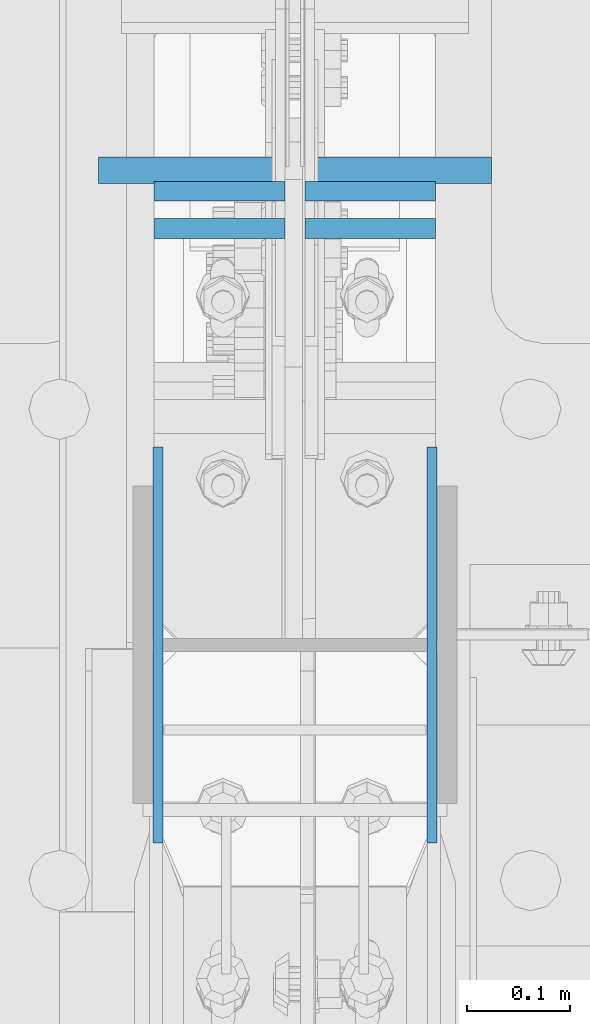
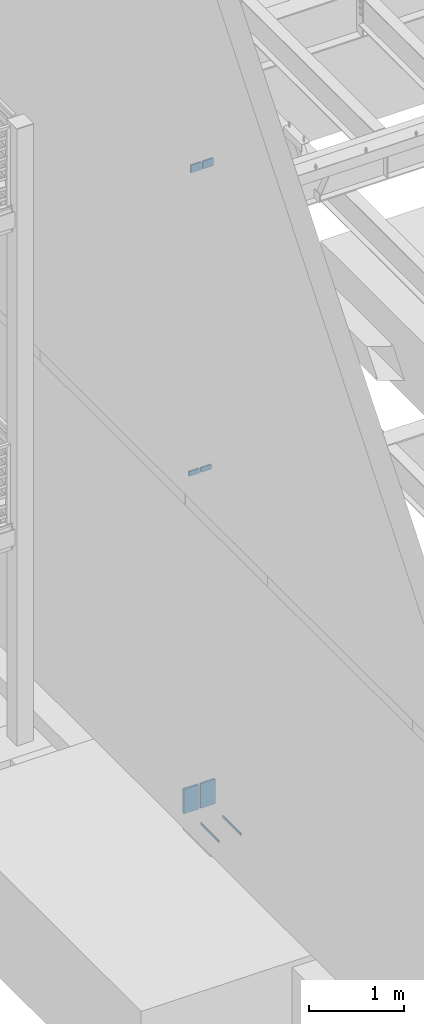
# One storey, part 422 of 1179: 8 columns, 3 elements without a shape of their own.
"""IFC2X3 building model written with IfcOpenShell, lengths in millimetres."""

from ifc_helpers import new_model, si_unit, frame, origin_with_axes, place, context, subcontext, project, spatial, faceted_brep, material, type_object, element, aggregate, save


model = new_model("IFC2X3")

# Units and contexts
model_context = context("Model", 3, precision=1e-05, world=origin_with_axes())
body_context = subcontext(model_context, "Body", "Model", "MODEL_VIEW")
ifc_project = project(units=[si_unit("LENGTHUNIT", "METRE", prefix="MILLI"), si_unit("AREAUNIT", "SQUARE_METRE"), si_unit("VOLUMEUNIT", "CUBIC_METRE"), si_unit("MASSUNIT", "GRAM", prefix="KILO"), si_unit("TIMEUNIT", "SECOND"), si_unit("PLANEANGLEUNIT", "RADIAN"), si_unit("SOLIDANGLEUNIT", "STERADIAN"), si_unit("THERMODYNAMICTEMPERATUREUNIT", "DEGREE_CELSIUS"), si_unit("LUMINOUSINTENSITYUNIT", "LUMEN")], contexts=[model_context])

# Site, building, storey
site_placement = place(None, origin_with_axes())
site = spatial("IfcSite", under=ifc_project, at=site_placement, CompositionType="ELEMENT")
building_placement = place(site_placement, origin_with_axes())
building = spatial("IfcBuilding", under=site, at=building_placement, Name="Undefined", CompositionType="ELEMENT")
storey_placement = place(building_placement, origin_with_axes())
storey = spatial("IfcBuildingStorey", under=building, at=storey_placement, Name="Undefined", CompositionType="ELEMENT", Elevation=0.0)

# Assembly, columns
assembly_1_placement = place(storey_placement, origin_with_axes())
assembly_1 = element("IfcElementAssembly", 1, at=assembly_1_placement, inside=storey, Name="COLUMN", AssemblyPlace="NOTDEFINED", PredefinedType="RIGID_FRAME")
ifc_material = material(Name="STEEL/A572-GR.50")
column_type_1 = type_object("IfcColumnType", PredefinedType="NOTDEFINED")
column_1_placement = place(assembly_1_placement, frame((564.753000000001, 27051.0, -215.9), z_axis=(0.0, -1.0, 0.0), x_axis=(0.0, 0.0, 1.0)))
column_1 = element("IfcColumn", 2, at=column_1_placement, type_object=column_type_1, material=ifc_material, Name="PLATE", context=body_context, shape_type="Brep", body=[
    faceted_brep([(0.0, 4.76249999999982, -192.087500000001), (0.0, 4.76249999999982, 192.0875), (31.75, 4.76249999999982, 192.0875), (31.75, 4.76249999999982, -192.087500000001), (0.0, -4.76249999999982, 192.0875), (31.75, -4.76249999999982, 192.0875), (0.0, -4.76249999999982, -192.087500000001), (31.75, -4.76249999999982, -192.087500000001)], [[[0, 1, 2, 3]], [[1, 4, 5, 2]], [[4, 6, 7, 5]], [[6, 0, 3, 7]], [[5, 7, 3, 2]], [[6, 4, 1, 0]]]),
])
column_2_placement = place(assembly_1_placement, frame((298.846874999998, 27051.0, -215.9), z_axis=(0.0, -1.0, 0.0), x_axis=(0.0, 0.0, 1.0)))
column_2 = element("IfcColumn", 3, at=column_2_placement, type_object=column_type_1, material=ifc_material, Name="PLATE", context=body_context, shape_type="Brep", body=[
    faceted_brep([(0.0, 4.76249999999982, -192.087500000001), (0.0, 4.76249999999982, 192.0875), (31.75, 4.76249999999982, 192.0875), (31.75, 4.76249999999982, -192.087500000001), (0.0, -4.76249999999982, 192.0875), (31.75, -4.76249999999982, 192.0875), (0.0, -4.76249999999982, -192.087500000001), (31.75, -4.76249999999982, -192.087500000001)], [[[0, 1, 2, 3]], [[1, 4, 5, 2]], [[4, 6, 7, 5]], [[6, 0, 3, 7]], [[5, 7, 3, 2]], [[6, 4, 1, 0]]]),
])
column_type_2 = type_object("IfcColumnType", PredefinedType="NOTDEFINED")
column_3_placement = place(assembly_1_placement, frame((358.774999999999, 27454.8139034115, 8013.7), z_axis=(-1.0, 0.0, 0.0), x_axis=(0.0, 0.0, 1.0)))
column_3 = element("IfcColumn", 4, at=column_3_placement, type_object=column_type_2, material=ifc_material, Name="PLATE", context=body_context, shape_type="Brep", body=[
    faceted_brep([(0.0, 9.52500000000146, -63.5), (0.0, 9.52500000000146, 63.5), (97.946337981949, 9.52500000000146, 63.5), (97.946337981949, 9.52500000000146, -63.5), (0.0, -9.52500000000146, 63.5), (97.946337981949, -9.52500000000146, 63.5), (0.0, -9.52500000000146, -63.5), (97.946337981949, -9.52500000000146, -63.5)], [[[0, 1, 2, 3]], [[1, 4, 5, 2]], [[4, 6, 7, 5]], [[6, 0, 3, 7]], [[5, 7, 3, 2]], [[6, 4, 1, 0]]]),
])
column_4_placement = place(assembly_1_placement, frame((504.824999999999, 27454.8139034115, 8013.7), z_axis=(-1.0, 0.0, 0.0), x_axis=(0.0, 0.0, 1.0)))
column_4 = element("IfcColumn", 5, at=column_4_placement, type_object=column_type_2, material=ifc_material, Name="PLATE", context=body_context, shape_type="Brep", body=[
    faceted_brep([(0.0, 9.52500000000146, -63.5), (0.0, 9.52500000000146, 63.5), (97.946337981949, 9.52500000000146, 63.5), (97.946337981949, 9.52500000000146, -63.5), (0.0, -9.52500000000146, 63.5), (97.946337981949, -9.52500000000146, 63.5), (0.0, -9.52500000000146, -63.5), (97.946337981949, -9.52500000000146, -63.5)], [[[0, 1, 2, 3]], [[1, 4, 5, 2]], [[4, 6, 7, 5]], [[6, 0, 3, 7]], [[5, 7, 3, 2]], [[6, 4, 1, 0]]]),
])

# Assembly, column
assembly_2_placement = place(storey_placement, origin_with_axes())
assembly_2 = element("IfcElementAssembly", 6, at=assembly_2_placement, inside=storey, Name="PLATE", AssemblyPlace="NOTDEFINED", PredefinedType="RIGID_FRAME")
column_type_3 = type_object("IfcColumnType", PredefinedType="NOTDEFINED")
column_5_placement = place(assembly_2_placement, frame((330.2, 27511.3198380769, -215.9), z_axis=(1.0, 0.0, 0.0), x_axis=(0.0, 0.0, 1.0)))
column_5 = element("IfcColumn", 7, at=column_5_placement, type_object=column_type_3, material=ifc_material, Name="PLATE", context=body_context, shape_type="Brep", body=[
    faceted_brep([(0.0, 12.6999999999998, -88.9000000000015), (0.0, 12.6999999999998, 88.9000000000015), (314.840055491836, 12.7000000000007, 88.9000000000015), (314.840055491836, 12.7000000000007, -88.9000000000015), (0.0, -12.6999999999998, 88.9000000000015), (314.840055491836, -12.7000000000007, 88.9000000000015), (0.0, -12.6999999999998, -88.9000000000015), (314.840055491836, -12.7000000000007, -88.9000000000015)], [[[0, 1, 2, 3]], [[1, 4, 5, 2]], [[4, 6, 7, 5]], [[6, 0, 3, 7]], [[5, 7, 3, 2]], [[6, 4, 1, 0]]]),
])
aggregate(assembly_2, [column_5])

assembly_3_placement = place(storey_placement, origin_with_axes())
assembly_3 = element("IfcElementAssembly", 8, at=assembly_3_placement, inside=storey, Name="PLATE", AssemblyPlace="NOTDEFINED", PredefinedType="RIGID_FRAME")
column_6_placement = place(assembly_3_placement, frame((533.4, 27511.3198380769, -215.9), z_axis=(-1.0, 0.0, 0.0), x_axis=(0.0, 0.0, 1.0)))
column_6 = element("IfcColumn", 9, at=column_6_placement, type_object=column_type_3, material=ifc_material, Name="PLATE", context=body_context, shape_type="Brep", body=[
    faceted_brep([(0.0, 12.6999999999998, -88.9000000000015), (0.0, 12.6999999999998, 88.9000000000015), (314.840055491836, 12.7000000000007, 88.9000000000015), (314.840055491836, 12.7000000000007, -88.9000000000015), (0.0, -12.6999999999998, 88.9000000000015), (314.840055491836, -12.7000000000007, 88.9000000000015), (0.0, -12.6999999999998, -88.9000000000015), (314.840055491836, -12.7000000000007, -88.9000000000015)], [[[0, 1, 2, 3]], [[1, 4, 5, 2]], [[4, 6, 7, 5]], [[6, 0, 3, 7]], [[5, 7, 3, 2]], [[6, 4, 1, 0]]]),
])
aggregate(assembly_3, [column_6])

# Column
column_type_4 = type_object("IfcColumnType", PredefinedType="NOTDEFINED")
column_7_placement = place(assembly_1_placement, frame((358.775000000002, 27490.958001131, 4102.1), z_axis=(1.0, 0.0, 0.0), x_axis=(0.0, 0.0, 1.0)))
column_7 = element("IfcColumn", 10, at=column_7_placement, type_object=column_type_4, material=ifc_material, Name="PLATE", context=body_context, shape_type="Brep", body=[
    faceted_brep([(0.0, 9.52500000000146, -63.5), (0.0, 9.52500000000146, 63.5), (59.8857973215509, 9.52500000000146, 63.5), (59.8857973215509, 9.52500000000146, -63.5), (0.0, -9.52500000000146, 63.5), (59.8857973215509, -9.52500000000146, 63.5), (0.0, -9.52500000000146, -63.5), (59.8857973215509, -9.52500000000146, -63.5)], [[[0, 1, 2, 3]], [[1, 4, 5, 2]], [[4, 6, 7, 5]], [[6, 0, 3, 7]], [[5, 7, 3, 2]], [[6, 4, 1, 0]]]),
])

column_8_placement = place(assembly_1_placement, frame((504.824713611823, 27490.958001131, 4102.1), z_axis=(-1.0, 0.0, 0.0), x_axis=(0.0, 0.0, 1.0)))
column_8 = element("IfcColumn", 11, at=column_8_placement, type_object=column_type_4, material=ifc_material, Name="PLATE", context=body_context, shape_type="Brep", body=[
    faceted_brep([(0.0, 9.52500000000146, -63.5), (0.0, 9.52500000000146, 63.5), (59.8857973215509, 9.52500000000146, 63.5), (59.8857973215509, 9.52500000000146, -63.5), (0.0, -9.52500000000146, 63.5), (59.8857973215509, -9.52500000000146, 63.5), (0.0, -9.52500000000146, -63.5), (59.8857973215509, -9.52500000000146, -63.5)], [[[0, 1, 2, 3]], [[1, 4, 5, 2]], [[4, 6, 7, 5]], [[6, 0, 3, 7]], [[5, 7, 3, 2]], [[6, 4, 1, 0]]]),
])

aggregate(assembly_1, [column_1, column_2, column_3, column_4, column_7, column_8])

save(model, "model.ifc")
